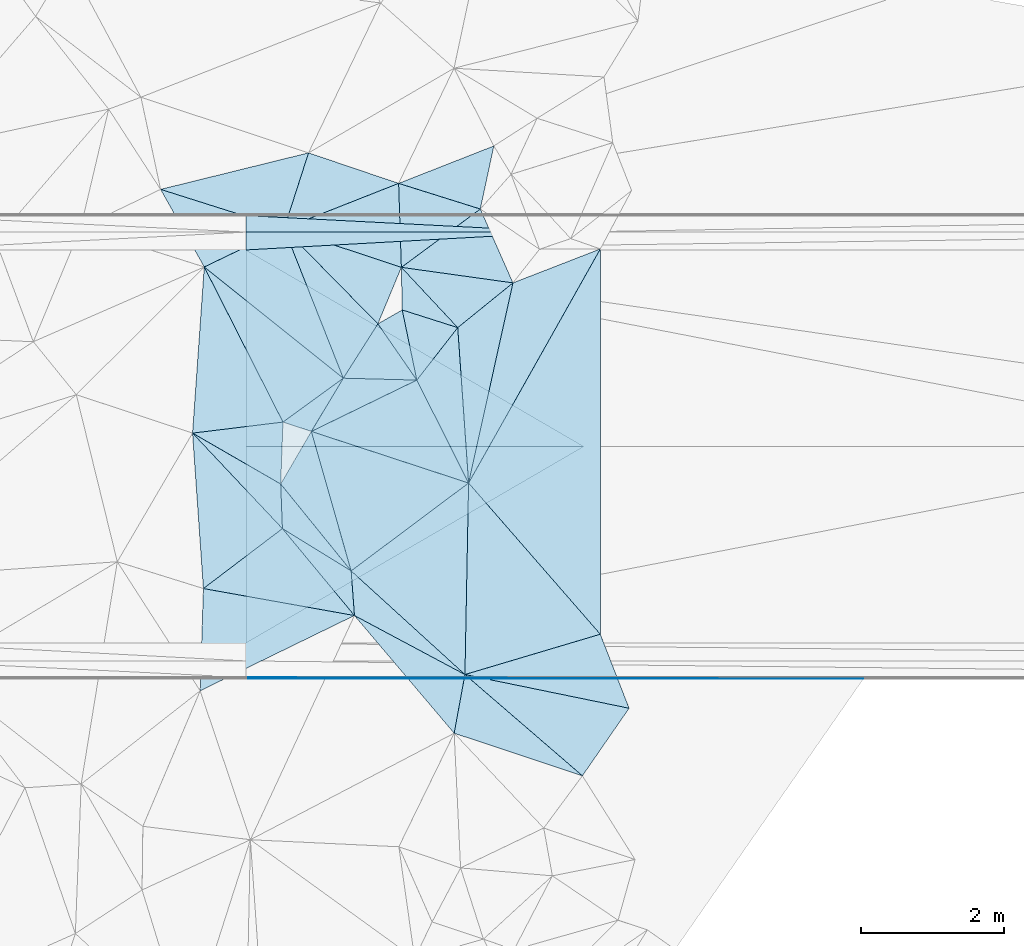
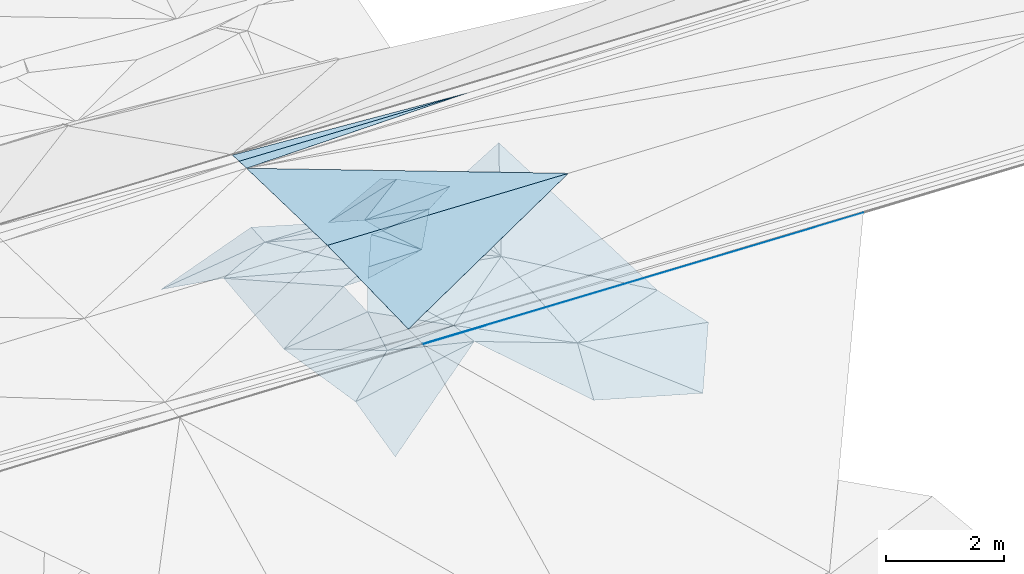
# One storey, part 106 of 275: 45 plates.
"""IFC2X3 building model written with IfcOpenShell, lengths in millimetres."""

from ifc_helpers import new_model, si_unit, frame, origin_with_axes, place, context, subcontext, project, spatial, polyline, outline, extrude, material, type_object, element, save


model = new_model("IFC2X3")

# Units and contexts
model_context = context("Model", 3, precision=1e-05, world=origin_with_axes())
body_context = subcontext(model_context, "Body", "Model", "MODEL_VIEW")
ifc_project = project(units=[si_unit("LENGTHUNIT", "METRE", prefix="MILLI"), si_unit("AREAUNIT", "SQUARE_METRE"), si_unit("VOLUMEUNIT", "CUBIC_METRE"), si_unit("MASSUNIT", "GRAM", prefix="KILO"), si_unit("TIMEUNIT", "SECOND"), si_unit("PLANEANGLEUNIT", "RADIAN"), si_unit("SOLIDANGLEUNIT", "STERADIAN"), si_unit("THERMODYNAMICTEMPERATUREUNIT", "DEGREE_CELSIUS"), si_unit("LUMINOUSINTENSITYUNIT", "LUMEN")], contexts=[model_context])

# Site, building, storey
site_placement = place(None, origin_with_axes())
site = spatial("IfcSite", under=ifc_project, at=site_placement, CompositionType="ELEMENT")
building_placement = place(site_placement, origin_with_axes())
building = spatial("IfcBuilding", under=site, at=building_placement, Name="Undefined", CompositionType="ELEMENT")
storey_placement = place(building_placement, origin_with_axes())
storey = spatial("IfcBuildingStorey", under=building, at=storey_placement, Name="Undefined", CompositionType="ELEMENT", Elevation=0.0)

# Plates
ifc_material = material()
plate_type_1 = type_object("IfcPlateType", PredefinedType="NOTDEFINED")
plate_1_placement = place(storey_placement, frame((-29430.5920355423, 63288.5642696594, 47999.1584437097), z_axis=(-0.0338599635667188, -0.0249758570214547, -0.999114462628434), x_axis=(-0.999426275850819, 5.723397562415e-05, 0.0338690989433678)))
element("IfcPlate", 1, at=plate_1_placement, inside=storey, type_object=plate_type_1, material=ifc_material, Name="00_PR", context=body_context, shape_type="SweptSolid", body=[
    extrude(outline(polyline([(0.0, 0.0), (4729.90234375, -2.35013430938125e-09), (4727.57373046875, 2750.8583984375), (0.0, 0.0)])), frame((-8.85201319254618e-08, 2.18876761149539e-07, -0.5000001331573), z_axis=(0.0, 0.0, 1.0), x_axis=(1.0, 0.0, 0.0)), (0.0, 0.0, 1.0), 1.0),
])
plate_2_placement = place(storey_placement, frame((-34157.7805495423, 63288.8599630013, 48159.3554430276), z_axis=(-0.0338571161760964, 0.0249801178898649, -0.999114452600125), x_axis=(0.999426275850804, -5.72339860804832e-05, -0.0338690989437899)))
element("IfcPlate", 2, at=plate_2_placement, inside=storey, type_object=plate_type_1, material=ifc_material, Name="00_PR", context=body_context, shape_type="SweptSolid", body=[
    extrude(outline(polyline([(0.0, 0.0), (4729.90234375, -2.35013430938125e-09), (2.32842135429382, 2750.8583984375), (0.0, 0.0)])), frame((-8.85201319254618e-08, 2.18876761149539e-07, -0.5000001331573), z_axis=(0.0, 0.0, 1.0), x_axis=(1.0, 0.0, 0.0)), (0.0, 0.0, 1.0), 1.0),
])
plate_type_2 = type_object("IfcPlateType", PredefinedType="NOTDEFINED")
plate_3_placement = place(storey_placement, frame((-29668.6868946436, 66288.5778176884, 47932.232445063), z_axis=(-0.0338599635667188, -0.0249758570214547, -0.999114462628434), x_axis=(-0.997837035378407, -0.0555148520448431, 0.0352044319606442)))
element("IfcPlate", 3, at=plate_3_placement, inside=storey, type_object=plate_type_2, material=ifc_material, Name="00_PR", context=body_context, shape_type="SweptSolid", body=[
    extrude(outline(polyline([(0.0, 0.0), (4498.66650390625, -3.66708263754845e-09), (4484.5537109375, 249.679565429688), (0.0, 0.0)])), frame((-8.85201319254618e-08, 2.18876761149539e-07, -0.5000001331573), z_axis=(0.0, 0.0, 1.0), x_axis=(1.0, 0.0, 0.0)), (0.0, 0.0, 1.0), 1.0),
])
plate_type_3 = type_object("IfcPlateType", PredefinedType="NOTDEFINED")
plate_4_placement = place(storey_placement, frame((-34906.5955251303, 63476.233108488, 46159.6915268774), z_axis=(0.645326928736443, 0.450496903413897, -0.616932488253035), x_axis=(0.761768392119548, -0.439883560517022, 0.475616831025214)))
element("IfcPlate", 4, at=plate_4_placement, inside=storey, type_object=plate_type_3, material=ifc_material, Name="00", context=body_context, shape_type="SweptSolid", body=[
    extrude(outline(polyline([(0.0, 0.0), (1618.95031738281, 4.04543243348598e-09), (1707.09387207031, 752.615905761719), (0.0, 0.0)])), frame((-8.85201319254618e-08, 2.18876761149539e-07, -0.5000001331573), z_axis=(0.0, 0.0, 1.0), x_axis=(1.0, 0.0, 0.0)), (0.0, 0.0, 1.0), 1.0),
])
plate_type_4 = type_object("IfcPlateType", PredefinedType="NOTDEFINED")
plate_5_placement = place(storey_placement, frame((-34157.9667410327, 60038.8724066972, 48071.8559097527), z_axis=(-0.0338239728075188, 0.0499100723519789, -0.998180807039154), x_axis=(5.44309859502141e-05, 0.9987523778888, 0.0499368070538782)))
element("IfcPlate", 5, at=plate_5_placement, inside=storey, type_object=plate_type_4, material=ifc_material, Name="00_PR", context=body_context, shape_type="SweptSolid", body=[
    extrude(outline(polyline([(0.0, 0.0), (20.0253086090088, -9.45874489843845e-11), (-14.6403675079346, 8642.0693359375), (0.0, 0.0)])), frame((-8.85201319254618e-08, 2.18876761149539e-07, -0.5000001331573), z_axis=(0.0, 0.0, 1.0), x_axis=(1.0, 0.0, 0.0)), (0.0, 0.0, 1.0), 1.0),
])
plate_type_5 = type_object("IfcPlateType", PredefinedType="NOTDEFINED")
plate_6_placement = place(storey_placement, frame((-33624.8761772922, 66338.7467241689, 46189.5202326448), z_axis=(0.257761214556939, -0.113494934874623, -0.959519700698186), x_axis=(0.676383358157667, -0.687965761393118, 0.263075395957403)))
element("IfcPlate", 6, at=plate_6_placement, inside=storey, type_object=plate_type_5, material=ifc_material, Name="00", context=body_context, shape_type="SweptSolid", body=[
    extrude(outline(polyline([(0.0, 0.0), (1938.60778808594, -6.40648067928851e-09), (2124.10180664063, 883.001708984375), (0.0, 0.0)])), frame((-8.85201319254618e-08, 2.18876761149539e-07, -0.5000001331573), z_axis=(0.0, 0.0, 1.0), x_axis=(1.0, 0.0, 0.0)), (0.0, 0.0, 1.0), 1.0),
])
plate_type_6 = type_object("IfcPlateType", PredefinedType="NOTDEFINED")
plate_7_placement = place(storey_placement, frame((-31769.0790445192, 64217.9882530285, 46669.5308423597), z_axis=(-0.0565490432140062, -0.341164686028548, -0.938301051218969), x_axis=(0.430553170639808, -0.856258654073629, 0.285385852095063)))
element("IfcPlate", 7, at=plate_7_placement, inside=storey, type_object=plate_type_6, material=ifc_material, Name="00", context=body_context, shape_type="SweptSolid", body=[
    extrude(outline(polyline([(0.0, 0.0), (1681.93347167969, -3.49427864421159e-09), (79.3134841918945, 1676.12927246094), (0.0, 0.0)])), frame((-8.85201319254618e-08, 2.18876761149539e-07, -0.5000001331573), z_axis=(0.0, 0.0, 1.0), x_axis=(1.0, 0.0, 0.0)), (0.0, 0.0, 1.0), 1.0),
])
plate_type_7 = type_object("IfcPlateType", PredefinedType="NOTDEFINED")
plate_8_placement = place(storey_placement, frame((-31044.8735231759, 62778.0164370905, 47149.5009978926), z_axis=(0.0309699019838671, 0.0552811849493041, -0.997990408652163), x_axis=(0.656670307456456, -0.75387463059103, -0.0213810349675273)))
element("IfcPlate", 8, at=plate_8_placement, inside=storey, type_object=plate_type_7, material=ifc_material, Name="00", context=body_context, shape_type="SweptSolid", body=[
    extrude(outline(polyline([(0.0, 0.0), (2806.22534179688, 6.51562004350126e-09), (1989.68347167969, 1801.51586914063), (0.0, 0.0)])), frame((-8.85201319254618e-08, 2.18876761149539e-07, -0.5000001331573), z_axis=(0.0, 0.0, 1.0), x_axis=(1.0, 0.0, 0.0)), (0.0, 0.0, 1.0), 1.0),
])
plate_type_8 = type_object("IfcPlateType", PredefinedType="NOTDEFINED")
plate_9_placement = place(storey_placement, frame((-29668.6868792815, 66288.5653521395, 47932.2329119963), z_axis=(-0.0338297481142317, -0.0499071816828997, -0.998180755854869), x_axis=(-0.999426275850819, 5.723397562415e-05, 0.0338690989433678)))
element("IfcPlate", 9, at=plate_9_placement, inside=storey, type_object=plate_type_8, material=ifc_material, Name="00_PR", context=body_context, shape_type="SweptSolid", body=[
    extrude(outline(polyline([(0.0, 0.0), (4491.49853515625, -4.35102265328169e-09), (4491.10888671875, 230.286666870117), (0.0, 0.0)])), frame((-8.85201319254618e-08, 2.18876761149539e-07, -0.5000001331573), z_axis=(0.0, 0.0, 1.0), x_axis=(1.0, 0.0, 0.0)), (0.0, 0.0, 1.0), 1.0),
])
plate_type_9 = type_object("IfcPlateType", PredefinedType="NOTDEFINED")
plate_10_placement = place(storey_placement, frame((-29201.732980358, 66052.9096600141, 46879.5018671347), z_axis=(-0.0769892395004935, -0.0388063541312116, -0.996276429451274), x_axis=(-7.96508297010918e-05, -0.999242014070851, 0.0389280229574273)))
element("IfcPlate", 10, at=plate_10_placement, inside=storey, type_object=plate_type_9, material=ifc_material, Name="00", context=body_context, shape_type="SweptSolid", body=[
    extrude(outline(polyline([(0.0, 0.0), (5394.5712890625, 5.3114490583539e-09), (3283.115234375, 1848.41918945313), (0.0, 0.0)])), frame((-8.85201319254618e-08, 2.18876761149539e-07, -0.5000001331573), z_axis=(0.0, 0.0, 1.0), x_axis=(1.0, 0.0, 0.0)), (0.0, 0.0, 1.0), 1.0),
])
plate_type_10 = type_object("IfcPlateType", PredefinedType="NOTDEFINED")
plate_11_placement = place(storey_placement, frame((-32641.4637179937, 60923.9539024116, 47069.5320459483), z_axis=(0.292678287468678, -0.196060035807474, -0.935895230463097), x_axis=(-0.930650963974518, 0.16638035242546, -0.325893175105094)))
element("IfcPlate", 11, at=plate_11_placement, inside=storey, type_object=plate_type_10, material=ifc_material, Name="00", context=body_context, shape_type="SweptSolid", body=[
    extrude(outline(polyline([(0.0, 0.0), (2270.6826171875, -2.9394868761301e-09), (1326.12097167969, 1030.34130859375), (0.0, 0.0)])), frame((-8.85201319254618e-08, 2.18876761149539e-07, -0.5000001331573), z_axis=(0.0, 0.0, 1.0), x_axis=(1.0, 0.0, 0.0)), (0.0, 0.0, 1.0), 1.0),
])
plate_type_11 = type_object("IfcPlateType", PredefinedType="NOTDEFINED")
plate_12_placement = place(storey_placement, frame((-30880.8488615042, 66611.3344699383, 46369.6190569817), z_axis=(0.299892347677666, -0.574121618459326, -0.761872001731276), x_axis=(-0.817693023375108, 0.256656107660786, -0.515272512292369)))
element("IfcPlate", 12, at=plate_12_placement, inside=storey, type_object=plate_type_11, material=ifc_material, Name="00", context=body_context, shape_type="SweptSolid", body=[
    extrude(outline(polyline([(0.0, 0.0), (1397.31884765625, 9.1313268058002e-10), (375.361724853516, 1010.44720458984), (0.0, 0.0)])), frame((-8.85201319254618e-08, 2.18876761149539e-07, -0.5000001331573), z_axis=(0.0, 0.0, 1.0), x_axis=(1.0, 0.0, 0.0)), (0.0, 0.0, 1.0), 1.0),
])
plate_type_12 = type_object("IfcPlateType", PredefinedType="NOTDEFINED")
plate_13_placement = place(storey_placement, frame((-31769.2139225963, 64218.0635502216, 46669.5370645596), z_axis=(-0.326304105800245, -0.190566581827374, -0.925856364901453), x_axis=(-0.568861013502324, 0.82183671065608, 0.0313299909847272)))
element("IfcPlate", 13, at=plate_13_placement, inside=storey, type_object=plate_type_12, material=ifc_material, Name="00", context=body_context, shape_type="SweptSolid", body=[
    extrude(outline(polyline([(0.0, 0.0), (957.548950195313, -3.37604433298111e-09), (918.490905761719, 421.633087158203), (0.0, 0.0)])), frame((-8.85201319254618e-08, 2.18876761149539e-07, -0.5000001331573), z_axis=(0.0, 0.0, 1.0), x_axis=(1.0, 0.0, 0.0)), (0.0, 0.0, 1.0), 1.0),
])
plate_type_13 = type_object("IfcPlateType", PredefinedType="NOTDEFINED")
plate_14_placement = place(storey_placement, frame((-30424.0174682261, 65577.9989080435, 46689.5192850326), z_axis=(0.146148675234217, -0.233067318877788, -0.961415721526543), x_axis=(-0.9741019215009, 0.135587149367649, -0.180946322025648)))
element("IfcPlate", 14, at=plate_14_placement, inside=storey, type_object=plate_type_13, material=ifc_material, Name="00", context=body_context, shape_type="SweptSolid", body=[
    extrude(outline(polyline([(0.0, 0.0), (1602.68530273438, -4.03451849706471e-09), (643.108215332031, 982.706420898438), (0.0, 0.0)])), frame((-8.85201319254618e-08, 2.18876761149539e-07, -0.5000001331573), z_axis=(0.0, 0.0, 1.0), x_axis=(1.0, 0.0, 0.0)), (0.0, 0.0, 1.0), 1.0),
])
plate_type_14 = type_object("IfcPlateType", PredefinedType="NOTDEFINED")
plate_15_placement = place(storey_placement, frame((-31985.3047561987, 65795.1497793541, 46399.5801334403), z_axis=(-0.0708681985482482, -0.53837755767683, -0.839718586089684), x_axis=(-0.942299053586078, 0.31226416025809, -0.120679691038266)))
element("IfcPlate", 15, at=plate_15_placement, inside=storey, type_object=plate_type_14, material=ifc_material, Name="00", context=body_context, shape_type="SweptSolid", body=[
    extrude(outline(polyline([(0.0, 0.0), (1740.14367675781, 5.82076609134674e-10), (493.464996337891, 1304.10595703125), (0.0, 0.0)])), frame((-8.85201319254618e-08, 2.18876761149539e-07, -0.5000001331573), z_axis=(0.0, 0.0, 1.0), x_axis=(1.0, 0.0, 0.0)), (0.0, 0.0, 1.0), 1.0),
])
plate_type_15 = type_object("IfcPlateType", PredefinedType="NOTDEFINED")
plate_16_placement = place(storey_placement, frame((-32313.7621044127, 65004.9299309225, 46699.5326682064), z_axis=(0.00187006657036651, -0.355567421303092, -0.934648763846019), x_axis=(-0.676383358153246, 0.6879657613968, -0.263075395959141)))
element("IfcPlate", 16, at=plate_16_placement, inside=storey, type_object=plate_type_15, material=ifc_material, Name="00", context=body_context, shape_type="SweptSolid", body=[
    extrude(outline(polyline([(0.0, 0.0), (1938.60778808594, -6.40648067928851e-09), (400.442016601563, 813.7236328125), (0.0, 0.0)])), frame((-8.85201319254618e-08, 2.18876761149539e-07, -0.5000001331573), z_axis=(0.0, 0.0, 1.0), x_axis=(1.0, 0.0, 0.0)), (0.0, 0.0, 1.0), 1.0),
])
plate_type_16 = type_object("IfcPlateType", PredefinedType="NOTDEFINED")
plate_17_placement = place(storey_placement, frame((-32688.0745880421, 61548.5859491457, 47039.5009483319), z_axis=(0.0613703272254056, 0.00727588516527401, -0.998088545386284), x_axis=(-0.274273768562399, 0.961601157747051, -0.00985460796331534)))
element("IfcPlate", 17, at=plate_17_placement, inside=storey, type_object=plate_type_16, material=ifc_material, Name="00", context=body_context, shape_type="SweptSolid", body=[
    extrude(outline(polyline([(0.0, 0.0), (2029.50732421875, -4.64387994725257e-09), (730.423583984375, 1920.98449707031), (0.0, 0.0)])), frame((-8.85201319254618e-08, 2.18876761149539e-07, -0.5000001331573), z_axis=(0.0, 0.0, 1.0), x_axis=(1.0, 0.0, 0.0)), (0.0, 0.0, 1.0), 1.0),
])
plate_type_17 = type_object("IfcPlateType", PredefinedType="NOTDEFINED")
plate_18_placement = place(storey_placement, frame((-34800.1006936439, 59871.3909626899, 46069.5384470111), z_axis=(0.351245149994808, 0.156611766461947, -0.923092410981042), x_axis=(0.0312461393522388, 0.983401300797638, 0.178733210022912)))
element("IfcPlate", 18, at=plate_18_placement, inside=storey, type_object=plate_type_17, material=ifc_material, Name="00", context=body_context, shape_type="SweptSolid", body=[
    extrude(outline(polyline([(0.0, 0.0), (1454.68212890625, -2.4156179279089e-09), (1281.44836425781, 2264.06494140625), (0.0, 0.0)])), frame((-8.85201319254618e-08, 2.18876761149539e-07, -0.5000001331573), z_axis=(0.0, 0.0, 1.0), x_axis=(1.0, 0.0, 0.0)), (0.0, 0.0, 1.0), 1.0),
])
plate_type_18 = type_object("IfcPlateType", PredefinedType="NOTDEFINED")
plate_19_placement = place(storey_placement, frame((-33649.249876689, 62140.3842226184, 46499.5633152897), z_axis=(0.48704918856252, -0.00569263127145447, -0.873355988054011), x_axis=(0.768226014284791, -0.472899338587405, 0.431503194124562)))
element("IfcPlate", 19, at=plate_19_placement, inside=storey, type_object=plate_type_18, material=ifc_material, Name="00", context=body_context, shape_type="SweptSolid", body=[
    extrude(outline(polyline([(0.0, 0.0), (1251.43920898438, -1.04773789644241e-09), (1595.44311523438, 524.1767578125), (0.0, 0.0)])), frame((-8.85201319254618e-08, 2.18876761149539e-07, -0.5000001331573), z_axis=(0.0, 0.0, 1.0), x_axis=(1.0, 0.0, 0.0)), (0.0, 0.0, 1.0), 1.0),
])
plate_type_19 = type_object("IfcPlateType", PredefinedType="NOTDEFINED")
plate_20_placement = place(storey_placement, frame((-28799.035065747, 59627.1005956703, 46909.5072630654), z_axis=(-0.00374093335156746, 0.169856934653886, -0.985461631504568), x_axis=(-0.978845798132003, 0.200971957389053, 0.0383559098775469)))
element("IfcPlate", 20, at=plate_20_placement, inside=storey, type_object=plate_type_19, material=ifc_material, Name="00", context=body_context, shape_type="SweptSolid", body=[
    extrude(outline(polyline([(0.0, 0.0), (2346.44409179688, 1.25874066725373e-09), (609.560668945313, 946.274719238281), (0.0, 0.0)])), frame((-8.85201319254618e-08, 2.18876761149539e-07, -0.5000001331573), z_axis=(0.0, 0.0, 1.0), x_axis=(1.0, 0.0, 0.0)), (0.0, 0.0, 1.0), 1.0),
])
plate_type_20 = type_object("IfcPlateType", PredefinedType="NOTDEFINED")
plate_21_placement = place(storey_placement, frame((-33244.7470872876, 63499.9418003961, 47019.5495899703), z_axis=(-0.00238198249931404, -0.434215815660703, -0.90080572355502), x_axis=(0.475717001733111, 0.791856823585677, -0.382957053992822)))
element("IfcPlate", 21, at=plate_21_placement, inside=storey, type_object=plate_type_20, material=ifc_material, Name="00", context=body_context, shape_type="SweptSolid", body=[
    extrude(outline(polyline([(0.0, 0.0), (940.053161621094, 1.56433088704944e-09), (1404.60131835938, 918.038635253906), (0.0, 0.0)])), frame((-8.85201319254618e-08, 2.18876761149539e-07, -0.5000001331573), z_axis=(0.0, 0.0, 1.0), x_axis=(1.0, 0.0, 0.0)), (0.0, 0.0, 1.0), 1.0),
])
plate_type_21 = type_object("IfcPlateType", PredefinedType="NOTDEFINED")
plate_22_placement = place(storey_placement, frame((-32023.4038678006, 66970.0035055876, 45649.6019891685), z_axis=(0.345643889800796, -0.49689208218863, -0.796007889471972), x_axis=(0.817693023380162, -0.256656107661117, 0.515272512284184)))
element("IfcPlate", 22, at=plate_22_placement, inside=storey, type_object=plate_type_21, material=ifc_material, Name="00", context=body_context, shape_type="SweptSolid", body=[
    extrude(outline(polyline([(0.0, 0.0), (1397.31884765625, 9.1313268058002e-10), (719.306091308594, 1194.48681640625), (0.0, 0.0)])), frame((-8.85201319254618e-08, 2.18876761149539e-07, -0.5000001331573), z_axis=(0.0, 0.0, 1.0), x_axis=(1.0, 0.0, 0.0)), (0.0, 0.0, 1.0), 1.0),
])
plate_type_22 = type_object("IfcPlateType", PredefinedType="NOTDEFINED")
plate_23_placement = place(storey_placement, frame((-29452.670353155, 58682.2905824616, 46239.6034072241), z_axis=(0.143402899491308, 0.591870054179234, -0.793174285629177), x_axis=(-0.947175495033902, 0.314395325350038, 0.0633574068702757)))
element("IfcPlate", 23, at=plate_23_placement, inside=storey, type_object=plate_type_22, material=ifc_material, Name="00", context=body_context, shape_type="SweptSolid", body=[
    extrude(outline(polyline([(0.0, 0.0), (1894.01684570313, -4.06726030632854e-09), (2049.8232421875, 1040.34814453125), (0.0, 0.0)])), frame((-8.85201319254618e-08, 2.18876761149539e-07, -0.5000001331573), z_axis=(0.0, 0.0, 1.0), x_axis=(1.0, 0.0, 0.0)), (0.0, 0.0, 1.0), 1.0),
])
plate_type_23 = type_object("IfcPlateType", PredefinedType="NOTDEFINED")
plate_24_placement = place(storey_placement, frame((-31044.9488551923, 62777.9212735134, 47149.5082011896), z_axis=(-0.119694956473981, -0.135044558124675, -0.983583288143715), x_axis=(-0.0692164036138009, 0.989430221382253, -0.127424198982134)))
element("IfcPlate", 24, at=plate_24_placement, inside=storey, type_object=plate_type_23, material=ifc_material, Name="00", context=body_context, shape_type="SweptSolid", body=[
    extrude(outline(polyline([(0.0, 0.0), (2197.384765625, -1.96450855582953e-10), (2786.17553710938, 821.538391113281), (0.0, 0.0)])), frame((-8.85201319254618e-08, 2.18876761149539e-07, -0.5000001331573), z_axis=(0.0, 0.0, 1.0), x_axis=(1.0, 0.0, 0.0)), (0.0, 0.0, 1.0), 1.0),
])
plate_type_24 = type_object("IfcPlateType", PredefinedType="NOTDEFINED")
plate_25_placement = place(storey_placement, frame((-31095.8274759579, 60098.6128340749, 46999.5009227045), z_axis=(0.0253717464315116, 0.0553961280953768, -0.998142045740513), x_axis=(-0.739238318434635, 0.673187816558069, 0.0185707349265759)))
element("IfcPlate", 25, at=plate_25_placement, inside=storey, type_object=plate_type_24, material=ifc_material, Name="00", context=body_context, shape_type="SweptSolid", body=[
    extrude(outline(polyline([(0.0, 0.0), (2153.9267578125, -3.23416315950453e-09), (1768.86242675781, 2018.76831054688), (0.0, 0.0)])), frame((-8.85201319254618e-08, 2.18876761149539e-07, -0.5000001331573), z_axis=(0.0, 0.0, 1.0), x_axis=(1.0, 0.0, 0.0)), (0.0, 0.0, 1.0), 1.0),
])
plate_type_25 = type_object("IfcPlateType", PredefinedType="NOTDEFINED")
plate_26_placement = place(storey_placement, frame((-32313.7575984631, 65005.1305223938, 46699.5005428806), z_axis=(0.0108825017718147, 0.0456126577119366, -0.998899923221361), x_axis=(0.568861013505743, -0.821836710653653, -0.0313299909863155)))
element("IfcPlate", 26, at=plate_26_placement, inside=storey, type_object=plate_type_25, material=ifc_material, Name="00", context=body_context, shape_type="SweptSolid", body=[
    extrude(outline(polyline([(0.0, 0.0), (957.548950195313, -3.37604433298111e-09), (351.104766845703, 831.159118652344), (0.0, 0.0)])), frame((-8.85201319254618e-08, 2.18876761149539e-07, -0.5000001331573), z_axis=(0.0, 0.0, 1.0), x_axis=(1.0, 0.0, 0.0)), (0.0, 0.0, 1.0), 1.0),
])
plate_type_26 = type_object("IfcPlateType", PredefinedType="NOTDEFINED")
plate_27_placement = place(storey_placement, frame((-34742.8308392823, 65800.6220444591, 46159.5611353366), z_axis=(0.226705468047746, -0.422163573562231, -0.877714388576614), x_axis=(-0.430593118320251, 0.764880583650393, -0.479110904916468)))
element("IfcPlate", 27, at=plate_27_placement, inside=storey, type_object=plate_type_26, material=ifc_material, Name="00", context=body_context, shape_type="SweptSolid", body=[
    extrude(outline(polyline([(0.0, 0.0), (1419.29565429688, 3.92378751712386e-09), (-84.2671508789063, 1238.14343261719), (0.0, 0.0)])), frame((-8.85201319254618e-08, 2.18876761149539e-07, -0.5000001331573), z_axis=(0.0, 0.0, 1.0), x_axis=(1.0, 0.0, 0.0)), (0.0, 0.0, 1.0), 1.0),
])
plate_type_27 = type_object("IfcPlateType", PredefinedType="NOTDEFINED")
plate_28_placement = place(storey_placement, frame((-31044.6762185872, 62777.9456767628, 47149.5495911163), z_axis=(0.425577797557997, -0.0862386871435665, -0.900803212175355), x_axis=(-0.430553170640469, 0.856258654073746, -0.285385852093716)))
element("IfcPlate", 28, at=plate_28_placement, inside=storey, type_object=plate_type_27, material=ifc_material, Name="00", context=body_context, shape_type="SweptSolid", body=[
    extrude(outline(polyline([(0.0, 0.0), (1681.93347167969, -3.49427864421159e-09), (2007.03540039063, 894.599731445313), (0.0, 0.0)])), frame((-8.85201319254618e-08, 2.18876761149539e-07, -0.5000001331573), z_axis=(0.0, 0.0, 1.0), x_axis=(1.0, 0.0, 0.0)), (0.0, 0.0, 1.0), 1.0),
])
plate_type_28 = type_object("IfcPlateType", PredefinedType="NOTDEFINED")
plate_29_placement = place(storey_placement, frame((-32641.4777139784, 60924.332981865, 47069.6082081472), z_axis=(0.264687255256122, 0.562100807910904, -0.783570889359023), x_axis=(0.881399618994373, -0.470682035287918, -0.0399140738812527)))
element("IfcPlate", 29, at=plate_29_placement, inside=storey, type_object=plate_type_28, material=ifc_material, Name="00", context=body_context, shape_type="SweptSolid", body=[
    extrude(outline(polyline([(0.0, 0.0), (1753.76733398438, 3.11410985887051e-09), (2032.82373046875, 1014.26208496094), (0.0, 0.0)])), frame((-8.85201319254618e-08, 2.18876761149539e-07, -0.5000001331573), z_axis=(0.0, 0.0, 1.0), x_axis=(1.0, 0.0, 0.0)), (0.0, 0.0, 1.0), 1.0),
])
plate_type_29 = type_object("IfcPlateType", PredefinedType="NOTDEFINED")
plate_30_placement = place(storey_placement, frame((-29452.7030255555, 58682.2647008208, 46239.5810094648), z_axis=(0.0780565821464743, 0.540107221097461, -0.837968591119017), x_axis=(-0.714789198736873, 0.616252660800961, 0.330619206073748)))
element("IfcPlate", 30, at=plate_30_placement, inside=storey, type_object=plate_type_29, material=ifc_material, Name="00", context=body_context, shape_type="SweptSolid", body=[
    extrude(outline(polyline([(0.0, 0.0), (2298.71704101563, 2.03726813197136e-10), (336.62255859375, 1286.85095214844), (0.0, 0.0)])), frame((-8.85201319254618e-08, 2.18876761149539e-07, -0.5000001331573), z_axis=(0.0, 0.0, 1.0), x_axis=(1.0, 0.0, 0.0)), (0.0, 0.0, 1.0), 1.0),
])
plate_type_30 = type_object("IfcPlateType", PredefinedType="NOTDEFINED")
plate_31_placement = place(storey_placement, frame((-34742.9624729065, 65800.6597211787, 46159.5313820864), z_axis=(-0.0365634825050332, -0.346813418769528, -0.937221192840034), x_axis=(0.765607943470832, -0.612474005655478, 0.196774158086618)))
element("IfcPlate", 31, at=plate_31_placement, inside=storey, type_object=plate_type_30, material=ifc_material, Name="00", context=body_context, shape_type="SweptSolid", body=[
    extrude(outline(polyline([(0.0, 0.0), (2540.98413085938, 7.40692485123873e-09), (2321.8564453125, 1052.79772949219), (0.0, 0.0)])), frame((-8.85201319254618e-08, 2.18876761149539e-07, -0.5000001331573), z_axis=(0.0, 0.0, 1.0), x_axis=(1.0, 0.0, 0.0)), (0.0, 0.0, 1.0), 1.0),
])
plate_type_31 = type_object("IfcPlateType", PredefinedType="NOTDEFINED")
plate_32_placement = place(storey_placement, frame((-33283.8907594056, 67396.9740119543, 45739.5375820579), z_axis=(-0.17963243964401, -0.335316614152023, -0.924821580036476), x_axis=(0.944976260868661, -0.320102275327282, -0.0674862928673739)))
element("IfcPlate", 32, at=plate_32_placement, inside=storey, type_object=plate_type_31, material=ifc_material, Name="00", context=body_context, shape_type="SweptSolid", body=[
    extrude(outline(polyline([(0.0, 0.0), (1333.60412597656, 6.25732354819775e-10), (-14.0221519470215, 1199.50134277344), (0.0, 0.0)])), frame((-8.85201319254618e-08, 2.18876761149539e-07, -0.5000001331573), z_axis=(0.0, 0.0, 1.0), x_axis=(1.0, 0.0, 0.0)), (0.0, 0.0, 1.0), 1.0),
])
plate_type_32 = type_object("IfcPlateType", PredefinedType="NOTDEFINED")
plate_33_placement = place(storey_placement, frame((-31973.0504546455, 65199.3642148819, 46539.5378227254), z_axis=(0.379072977929162, -0.0435797024367149, -0.924340027770866), x_axis=(0.883135956494757, -0.281279673299365, 0.375436582840156)))
element("IfcPlate", 33, at=plate_33_placement, inside=storey, type_object=plate_type_32, material=ifc_material, Name="00", context=body_context, shape_type="SweptSolid", body=[
    extrude(outline(polyline([(0.0, 0.0), (878.976684570313, -3.63797880709171e-10), (505.132843017578, 875.351806640625), (0.0, 0.0)])), frame((-8.85201319254618e-08, 2.18876761149539e-07, -0.5000001331573), z_axis=(0.0, 0.0, 1.0), x_axis=(1.0, 0.0, 0.0)), (0.0, 0.0, 1.0), 1.0),
])
plate_type_33 = type_object("IfcPlateType", PredefinedType="NOTDEFINED")
plate_34_placement = place(storey_placement, frame((-31095.8769468405, 60098.5584777349, 46999.5020619076), z_axis=(-0.0735683902727609, -0.0533144605464529, -0.995864077195937), x_axis=(-0.881399618995955, 0.47068203528465, 0.0399140738848329)))
element("IfcPlate", 34, at=plate_34_placement, inside=storey, type_object=plate_type_33, material=ifc_material, Name="00", context=body_context, shape_type="SweptSolid", body=[
    extrude(outline(polyline([(0.0, 0.0), (1753.76733398438, 3.11410985887051e-09), (2087.50610351563, 530.771606445313), (0.0, 0.0)])), frame((-8.85201319254618e-08, 2.18876761149539e-07, -0.5000001331573), z_axis=(0.0, 0.0, 1.0), x_axis=(1.0, 0.0, 0.0)), (0.0, 0.0, 1.0), 1.0),
])
plate_type_34 = type_object("IfcPlateType", PredefinedType="NOTDEFINED")
plate_35_placement = place(storey_placement, frame((-31985.1067751148, 65795.3139587366, 46399.5389600444), z_axis=(0.325094889569202, -0.21001946191636, -0.922065690931156), x_axis=(0.632472642062326, -0.676590097344095, 0.377099717871293)))
element("IfcPlate", 35, at=plate_35_placement, inside=storey, type_object=plate_type_34, material=ifc_material, Name="00", context=body_context, shape_type="SweptSolid", body=[
    extrude(outline(polyline([(0.0, 0.0), (1246.35473632813, -1.06228981167078e-09), (463.672180175781, 400.010131835938), (0.0, 0.0)])), frame((-8.85201319254618e-08, 2.18876761149539e-07, -0.5000001331573), z_axis=(0.0, 0.0, 1.0), x_axis=(1.0, 0.0, 0.0)), (0.0, 0.0, 1.0), 1.0),
])
plate_type_35 = type_object("IfcPlateType", PredefinedType="NOTDEFINED")
plate_36_placement = place(storey_placement, frame((-31196.9275559571, 64951.9472325489, 46869.5454545981), z_axis=(0.113051961446759, -0.400996690803139, -0.909076953826227), x_axis=(-0.632472642060857, 0.676590097345008, -0.377099717872119)))
element("IfcPlate", 36, at=plate_36_placement, inside=storey, type_object=plate_type_35, material=ifc_material, Name="00", context=body_context, shape_type="SweptSolid", body=[
    extrude(outline(polyline([(0.0, 0.0), (1246.35473632813, -1.06228981167078e-09), (2.56748747825623, 1010.73901367188), (0.0, 0.0)])), frame((-8.85201319254618e-08, 2.18876761149539e-07, -0.5000001331573), z_axis=(0.0, 0.0, 1.0), x_axis=(1.0, 0.0, 0.0)), (0.0, 0.0, 1.0), 1.0),
])
plate_type_36 = type_object("IfcPlateType", PredefinedType="NOTDEFINED")
plate_37_placement = place(storey_placement, frame((-34742.6852901766, 65800.8148682687, 46159.5726335199), z_axis=(0.517804061328061, -0.0365216272905082, -0.854719325165998), x_axis=(0.432045692464601, -0.851156141730708, 0.298110284990099)))
element("IfcPlate", 37, at=plate_37_placement, inside=storey, type_object=plate_type_36, material=ifc_material, Name="00", context=body_context, shape_type="SweptSolid", body=[
    extrude(outline(polyline([(0.0, 0.0), (2549.39208984375, -2.02635419555008e-08), (1907.94506835938, 1338.44897460938), (0.0, 0.0)])), frame((-8.85201319254618e-08, 2.18876761149539e-07, -0.5000001331573), z_axis=(0.0, 0.0, 1.0), x_axis=(1.0, 0.0, 0.0)), (0.0, 0.0, 1.0), 1.0),
])
plate_type_37 = type_object("IfcPlateType", PredefinedType="NOTDEFINED")
plate_38_placement = place(storey_placement, frame((-33244.7118001706, 63499.9252737159, 47019.5592528406), z_axis=(0.06819418557043, -0.467269461165185, -0.88148102856317), x_axis=(-0.923661090130205, 0.304384047437874, -0.232810099104012)))
element("IfcPlate", 38, at=plate_38_placement, inside=storey, type_object=plate_type_37, material=ifc_material, Name="00", context=body_context, shape_type="SweptSolid", body=[
    extrude(outline(polyline([(0.0, 0.0), (429.534637451172, -8.33097146824002e-10), (-102.669250488281, 934.429809570313), (0.0, 0.0)])), frame((-8.85201319254618e-08, 2.18876761149539e-07, -0.5000001331573), z_axis=(0.0, 0.0, 1.0), x_axis=(1.0, 0.0, 0.0)), (0.0, 0.0, 1.0), 1.0),
])
plate_type_38 = type_object("IfcPlateType", PredefinedType="NOTDEFINED")
plate_39_placement = place(storey_placement, frame((-29201.5804311475, 66052.8256849357, 46879.5243085972), z_axis=(0.22823584076465, -0.206890161271508, -0.951369992253015), x_axis=(-0.48921054448166, -0.869216666305104, 0.071661915864706)))
element("IfcPlate", 39, at=plate_39_placement, inside=storey, type_object=plate_type_38, material=ifc_material, Name="00", context=body_context, shape_type="SweptSolid", body=[
    extrude(outline(polyline([(0.0, 0.0), (3767.69165039063, 5.97356120124459e-09), (997.109191894531, 872.681640625), (0.0, 0.0)])), frame((-8.85201319254618e-08, 2.18876761149539e-07, -0.5000001331573), z_axis=(0.0, 0.0, 1.0), x_axis=(1.0, 0.0, 0.0)), (0.0, 0.0, 1.0), 1.0),
])
plate_type_39 = type_object("IfcPlateType", PredefinedType="NOTDEFINED")
plate_40_placement = place(storey_placement, frame((-32797.4912019832, 64244.4585688691, 46659.5109032986), z_axis=(0.110818796110468, -0.175740719651135, -0.978179121574943), x_axis=(-0.765607943473189, 0.61247400565145, -0.196774158089984)))
element("IfcPlate", 40, at=plate_40_placement, inside=storey, type_object=plate_type_39, material=ifc_material, Name="00", context=body_context, shape_type="SweptSolid", body=[
    extrude(outline(polyline([(0.0, 0.0), (2540.98413085938, 7.40692485123873e-09), (2008.67065429688, 1121.04516601563), (0.0, 0.0)])), frame((-8.85201319254618e-08, 2.18876761149539e-07, -0.5000001331573), z_axis=(0.0, 0.0, 1.0), x_axis=(1.0, 0.0, 0.0)), (0.0, 0.0, 1.0), 1.0),
])
plate_type_40 = type_object("IfcPlateType", PredefinedType="NOTDEFINED")
plate_41_placement = place(storey_placement, frame((-33673.3944083112, 62763.8437219957, 46929.572325116), z_axis=(0.517259708720457, -0.0290525331032771, -0.855335223204745), x_axis=(-0.761768392117353, 0.439883560523496, -0.475616831022741)))
element("IfcPlate", 41, at=plate_41_placement, inside=storey, type_object=plate_type_40, material=ifc_material, Name="00", context=body_context, shape_type="SweptSolid", body=[
    extrude(outline(polyline([(0.0, 0.0), (1618.95031738281, 4.04543243348598e-09), (361.654083251953, 788.737182617188), (0.0, 0.0)])), frame((-8.85201319254618e-08, 2.18876761149539e-07, -0.5000001331573), z_axis=(0.0, 0.0, 1.0), x_axis=(1.0, 0.0, 0.0)), (0.0, 0.0, 1.0), 1.0),
])
plate_type_41 = type_object("IfcPlateType", PredefinedType="NOTDEFINED")
plate_42_placement = place(storey_placement, frame((-33283.6919203149, 67396.9213874437, 45739.5645763303), z_axis=(0.218049650596033, -0.440572194698305, -0.870833216599865), x_axis=(-0.284435540672847, -0.882254894668698, 0.375130276084548)))
element("IfcPlate", 42, at=plate_42_placement, inside=storey, type_object=plate_type_41, material=ifc_material, Name="00", context=body_context, shape_type="SweptSolid", body=[
    extrude(outline(polyline([(0.0, 0.0), (1199.58325195313, 1.44063960760832e-09), (941.910461425781, 1930.62292480469), (0.0, 0.0)])), frame((-8.85201319254618e-08, 2.18876761149539e-07, -0.5000001331573), z_axis=(0.0, 0.0, 1.0), x_axis=(1.0, 0.0, 0.0)), (0.0, 0.0, 1.0), 1.0),
])
plate_type_42 = type_object("IfcPlateType", PredefinedType="NOTDEFINED")
plate_43_placement = place(storey_placement, frame((-33244.6704761243, 63500.1753583668, 47019.5059881218), z_axis=(0.150842441430944, 0.0328989530728786, -0.988010231095742), x_axis=(0.274273768563162, -0.961601157746669, 0.0098546079793137)))
element("IfcPlate", 43, at=plate_43_placement, inside=storey, type_object=plate_type_42, material=ifc_material, Name="00", context=body_context, shape_type="SweptSolid", body=[
    extrude(outline(polyline([(0.0, 0.0), (2029.50732421875, -4.64387994725257e-09), (589.502685546875, 621.84130859375), (0.0, 0.0)])), frame((-8.85201319254618e-08, 2.18876761149539e-07, -0.5000001331573), z_axis=(0.0, 0.0, 1.0), x_axis=(1.0, 0.0, 0.0)), (0.0, 0.0, 1.0), 1.0),
])
plate_type_43 = type_object("IfcPlateType", PredefinedType="NOTDEFINED")
plate_44_placement = place(storey_placement, frame((-33649.3944164327, 62140.3557493391, 46499.5108906048), z_axis=(0.197967402909053, -0.0626380218908355, -0.978205185837331), x_axis=(-0.790772927818051, -0.599905399635586, -0.12162108418418)))
element("IfcPlate", 44, at=plate_44_placement, inside=storey, type_object=plate_type_43, material=ifc_material, Name="00", context=body_context, shape_type="SweptSolid", body=[
    extrude(outline(polyline([(0.0, 0.0), (1397.78393554688, 3.9945007301867e-09), (234.442520141602, 1850.84753417969), (0.0, 0.0)])), frame((-8.85201319254618e-08, 2.18876761149539e-07, -0.5000001331573), z_axis=(0.0, 0.0, 1.0), x_axis=(1.0, 0.0, 0.0)), (0.0, 0.0, 1.0), 1.0),
])
plate_type_44 = type_object("IfcPlateType", PredefinedType="NOTDEFINED")
plate_45_placement = place(storey_placement, frame((-32687.7890485406, 61548.810430761, 47039.6870036374), z_axis=(0.632452857687172, 0.456237735404735, -0.625979641518867), x_axis=(-0.768226014284495, 0.472899338588838, -0.431503194123518)))
element("IfcPlate", 45, at=plate_45_placement, inside=storey, type_object=plate_type_44, material=ifc_material, Name="00", context=body_context, shape_type="SweptSolid", body=[
    extrude(outline(polyline([(0.0, 0.0), (1251.43920898438, -1.04773789644241e-09), (1379.2919921875, 746.89599609375), (0.0, 0.0)])), frame((-8.85201319254618e-08, 2.18876761149539e-07, -0.5000001331573), z_axis=(0.0, 0.0, 1.0), x_axis=(1.0, 0.0, 0.0)), (0.0, 0.0, 1.0), 1.0),
])

save(model, "model.ifc")
